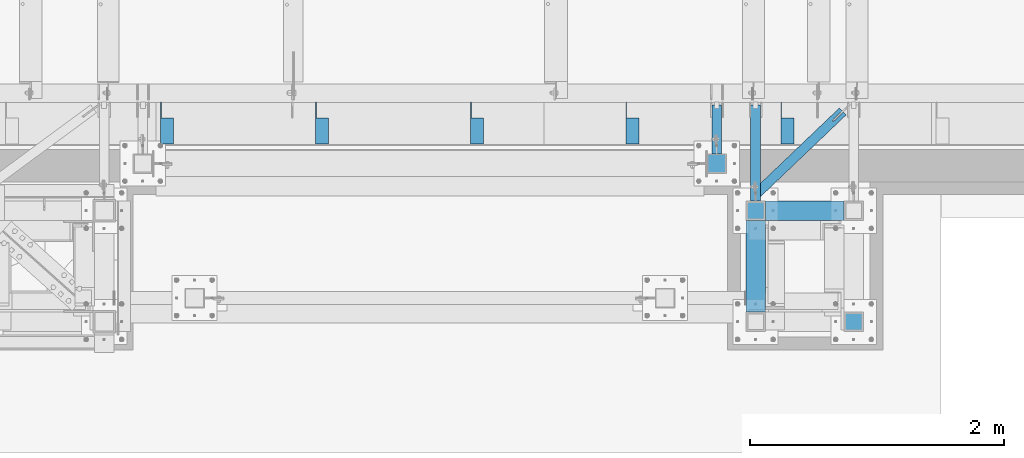
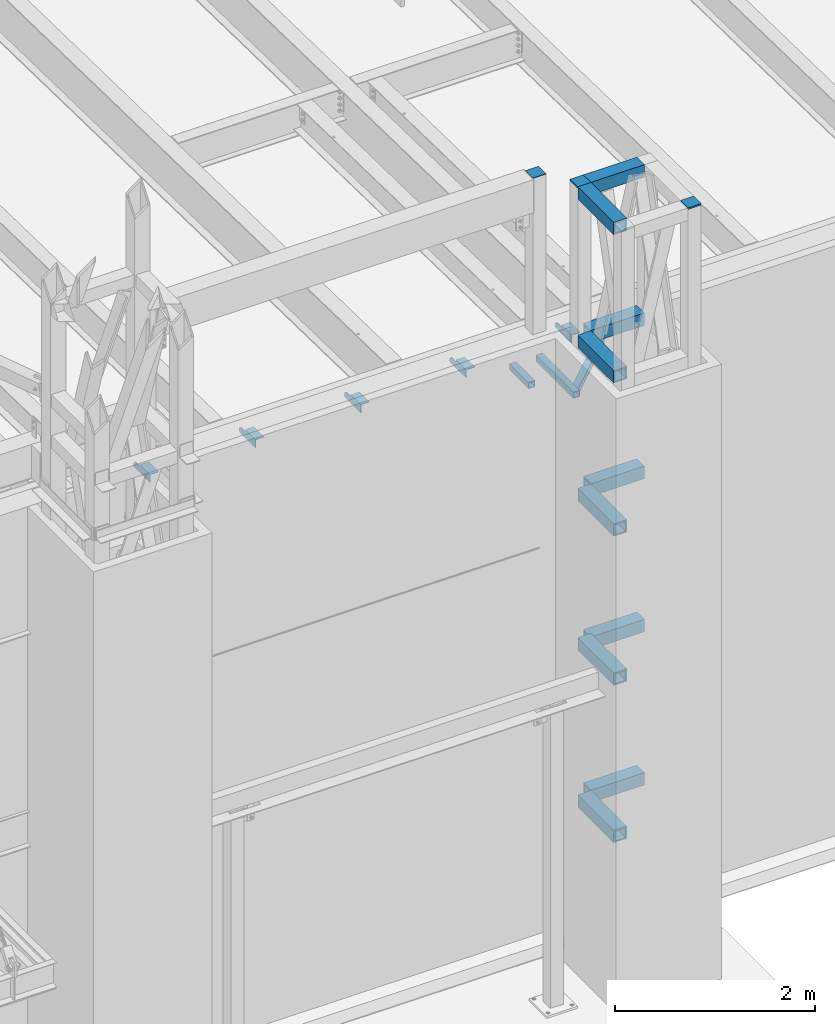
# One storey, part 1211 of 1763: 21 beams, 6 elements without a shape of their own.
"""IFC2X3 building model written with IfcOpenShell, lengths in millimetres."""

from ifc_helpers import new_model, si_unit, frame, origin_with_axes, place, context, subcontext, project, spatial, faceted_brep, material, type_object, element, aggregate, save


model = new_model("IFC2X3")

# Units and contexts
model_context = context("Model", 3, precision=1e-05, world=origin_with_axes())
body_context = subcontext(model_context, "Body", "Model", "MODEL_VIEW")
ifc_project = project(units=[si_unit("LENGTHUNIT", "METRE", prefix="MILLI"), si_unit("AREAUNIT", "SQUARE_METRE"), si_unit("VOLUMEUNIT", "CUBIC_METRE"), si_unit("MASSUNIT", "GRAM", prefix="KILO"), si_unit("TIMEUNIT", "SECOND"), si_unit("PLANEANGLEUNIT", "RADIAN"), si_unit("SOLIDANGLEUNIT", "STERADIAN"), si_unit("THERMODYNAMICTEMPERATUREUNIT", "DEGREE_CELSIUS"), si_unit("LUMINOUSINTENSITYUNIT", "LUMEN")], contexts=[model_context])

# Site, building, storey
site_placement = place(None, origin_with_axes())
site = spatial("IfcSite", under=ifc_project, at=site_placement, CompositionType="ELEMENT")
building_placement = place(site_placement, origin_with_axes())
building = spatial("IfcBuilding", under=site, at=building_placement, Name="Undefined", CompositionType="ELEMENT")
storey_placement = place(building_placement, origin_with_axes())
storey = spatial("IfcBuildingStorey", under=building, at=storey_placement, Name="Undefined", CompositionType="ELEMENT", Elevation=0.0)

# Assembly, beams
assembly_1_placement = place(storey_placement, origin_with_axes())
assembly_1 = element("IfcElementAssembly", 1, at=assembly_1_placement, inside=storey, Name="BEAM", AssemblyPlace="NOTDEFINED", PredefinedType="RIGID_FRAME")
ifc_material_1 = material(Name="STEEL/A36")
beam_type_1 = type_object("IfcBeamType", Name="L4X4X1/4", PredefinedType="NOTDEFINED")
beam_1_placement = place(assembly_1_placement, frame((-41389.6055562795, -13723.9373186166, 12153.8999999999), z_axis=(0.0, 0.0, -1.0), x_axis=(0.0, -1.0, 0.0)))
beam_1 = element("IfcBeam", 2, at=beam_1_placement, type_object=beam_type_1, material=ifc_material_1, Name="BRACE", ObjectType="L4X4X1/4", context=body_context, shape_type="Brep", body=[
    faceted_brep([(126.999999999967, 44.4499999999971, -25.4000000000069), (126.999999999967, 50.8000000000029, -25.4000000000069), (127.0, 50.7999999999993, -50.7999999999993), (127.0, -50.7999999999993, -50.7999999999993), (126.999999999965, -50.8000000000029, -44.4500000000007), (126.999999999965, 44.4499999999971, -44.4500000000007), (31.7499999999691, 44.4499999999971, -25.3999994277547), (31.7499999999691, 50.8000000000029, -25.3999994277547), (-1.81898940354586e-10, 44.4500000000371, 50.7999999999374), (-1.96450855582952e-10, 50.8000000000393, 50.7999999999374), (0.0, 50.8000000000029, 6.35000057224534), (0.0, 44.4499999999971, 6.35000057224534), (328.612481689444, 44.4499999999971, 50.7999999999993), (328.612481689444, 50.8000000000029, 50.7999999999993), (328.612512206997, 44.4499999999971, -44.4500000000007), (328.612512206997, -50.8000000000029, -44.4500000000007), (328.612512206997, -50.8000000000029, -50.7999999999993), (328.612512206997, 50.8000000000029, -50.7999999999993)], [[[0, 1, 2, 3, 4, 5]], [[6, 7, 1, 0]], [[8, 9, 10, 11]], [[9, 8, 12, 13]], [[12, 14, 15, 16, 17, 13]], [[15, 14, 5, 4]], [[16, 15, 4, 3]], [[17, 16, 3, 2]], [[10, 9, 13, 17, 2, 1, 7]], [[11, 10, 7, 6]], [[14, 12, 8, 11, 6, 0, 5]]]),
])
beam_2_placement = place(assembly_1_placement, frame((-42608.8055562795, -13723.9373186167, 12153.8999999999), z_axis=(0.0, 0.0, -1.0), x_axis=(0.0, -1.0, 0.0)))
beam_2 = element("IfcBeam", 3, at=beam_2_placement, type_object=beam_type_1, material=ifc_material_1, Name="BRACE", ObjectType="L4X4X1/4", context=body_context, shape_type="Brep", body=[
    faceted_brep([(126.999999999967, 44.4499999999971, -25.4000000000069), (126.999999999967, 50.8000000000029, -25.4000000000069), (127.0, 50.7999999999993, -50.7999999999993), (127.0, -50.7999999999993, -50.7999999999993), (126.999999999965, -50.8000000000029, -44.4500000000007), (126.999999999965, 44.4499999999971, -44.4500000000007), (31.7499999999691, 44.4499999999971, -25.3999994277547), (31.7499999999691, 50.8000000000029, -25.3999994277547), (-1.81898940354586e-10, 44.4500000000371, 50.7999999999374), (-1.96450855582952e-10, 50.8000000000393, 50.7999999999374), (0.0, 50.8000000000029, 6.35000057224534), (0.0, 44.4499999999971, 6.35000057224534), (328.612481689444, 44.4499999999971, 50.7999999999993), (328.612481689444, 50.8000000000029, 50.7999999999993), (328.612512206997, 44.4499999999971, -44.4500000000007), (328.612512206997, -50.8000000000029, -44.4500000000007), (328.612512206997, -50.8000000000029, -50.7999999999993), (328.612512206997, 50.8000000000029, -50.7999999999993)], [[[0, 1, 2, 3, 4, 5]], [[6, 7, 1, 0]], [[8, 9, 10, 11]], [[9, 8, 12, 13]], [[12, 14, 15, 16, 17, 13]], [[15, 14, 5, 4]], [[16, 15, 4, 3]], [[17, 16, 3, 2]], [[10, 9, 13, 17, 2, 1, 7]], [[11, 10, 7, 6]], [[14, 12, 8, 11, 6, 0, 5]]]),
])
beam_3_placement = place(assembly_1_placement, frame((-43828.0055562796, -13723.9373186167, 12153.8999999999), z_axis=(0.0, 0.0, -1.0), x_axis=(0.0, -1.0, 0.0)))
beam_3 = element("IfcBeam", 4, at=beam_3_placement, type_object=beam_type_1, material=ifc_material_1, Name="BRACE", ObjectType="L4X4X1/4", context=body_context, shape_type="Brep", body=[
    faceted_brep([(126.999999999967, 44.4499999999971, -25.4000000000069), (126.999999999967, 50.8000000000029, -25.4000000000069), (127.0, 50.7999999999993, -50.7999999999993), (127.0, -50.7999999999993, -50.7999999999993), (126.999999999965, -50.8000000000029, -44.4500000000007), (126.999999999965, 44.4499999999971, -44.4500000000007), (31.7499999999691, 44.4499999999971, -25.3999994277547), (31.7499999999691, 50.8000000000029, -25.3999994277547), (-1.81898940354586e-10, 44.4500000000371, 50.7999999999374), (-1.96450855582952e-10, 50.8000000000393, 50.7999999999374), (0.0, 50.8000000000029, 6.35000057224534), (0.0, 44.4499999999971, 6.35000057224534), (328.612481689444, 44.4499999999971, 50.7999999999993), (328.612481689444, 50.8000000000029, 50.7999999999993), (328.612512206997, 44.4499999999971, -44.4500000000007), (328.612512206997, -50.8000000000029, -44.4500000000007), (328.612512206997, -50.8000000000029, -50.7999999999993), (328.612512206997, 50.8000000000029, -50.7999999999993)], [[[0, 1, 2, 3, 4, 5]], [[6, 7, 1, 0]], [[8, 9, 10, 11]], [[9, 8, 12, 13]], [[12, 14, 15, 16, 17, 13]], [[15, 14, 5, 4]], [[16, 15, 4, 3]], [[17, 16, 3, 2]], [[10, 9, 13, 17, 2, 1, 7]], [[11, 10, 7, 6]], [[14, 12, 8, 11, 6, 0, 5]]]),
])
beam_4_placement = place(assembly_1_placement, frame((-45047.2055562796, -13723.9373186168, 12153.8999999999), z_axis=(0.0, 0.0, -1.0), x_axis=(0.0, -1.0, 0.0)))
beam_4 = element("IfcBeam", 5, at=beam_4_placement, type_object=beam_type_1, material=ifc_material_1, Name="BRACE", ObjectType="L4X4X1/4", context=body_context, shape_type="Brep", body=[
    faceted_brep([(126.999999999967, 44.4499999999971, -25.4000000000069), (126.999999999967, 50.8000000000029, -25.4000000000069), (127.0, 50.7999999999993, -50.7999999999993), (127.0, -50.7999999999993, -50.7999999999993), (126.999999999965, -50.8000000000029, -44.4500000000007), (126.999999999965, 44.4499999999971, -44.4500000000007), (31.7499999999691, 44.4499999999971, -25.3999994277547), (31.7499999999691, 50.8000000000029, -25.3999994277547), (-1.81898940354586e-10, 44.4500000000371, 50.7999999999374), (-1.96450855582952e-10, 50.8000000000393, 50.7999999999374), (0.0, 50.8000000000029, 6.35000057224534), (0.0, 44.4499999999971, 6.35000057224534), (328.612481689444, 44.4499999999971, 50.7999999999993), (328.612481689444, 50.8000000000029, 50.7999999999993), (328.612512206997, 44.4499999999971, -44.4500000000007), (328.612512206997, -50.8000000000029, -44.4500000000007), (328.612512206997, -50.8000000000029, -50.7999999999993), (328.612512206997, 50.8000000000029, -50.7999999999993)], [[[0, 1, 2, 3, 4, 5]], [[6, 7, 1, 0]], [[8, 9, 10, 11]], [[9, 8, 12, 13]], [[12, 14, 15, 16, 17, 13]], [[15, 14, 5, 4]], [[16, 15, 4, 3]], [[17, 16, 3, 2]], [[10, 9, 13, 17, 2, 1, 7]], [[11, 10, 7, 6]], [[14, 12, 8, 11, 6, 0, 5]]]),
])
beam_5_placement = place(assembly_1_placement, frame((-46266.4055562795, -13723.9373186169, 12153.8999999999), z_axis=(0.0, 0.0, -1.0), x_axis=(0.0, -1.0, 0.0)))
beam_5 = element("IfcBeam", 6, at=beam_5_placement, type_object=beam_type_1, material=ifc_material_1, Name="BRACE", ObjectType="L4X4X1/4", context=body_context, shape_type="Brep", body=[
    faceted_brep([(126.999999999967, 44.4499999999971, -25.4000000000069), (126.999999999967, 50.8000000000029, -25.4000000000069), (127.0, 50.7999999999993, -50.7999999999993), (127.0, -50.7999999999993, -50.7999999999993), (126.999999999965, -50.8000000000029, -44.4500000000007), (126.999999999965, 44.4499999999971, -44.4500000000007), (31.7499999999691, 44.4499999999971, -25.3999994277547), (31.7499999999691, 50.8000000000029, -25.3999994277547), (-1.81898940354586e-10, 44.4500000000371, 50.7999999999374), (-1.96450855582952e-10, 50.8000000000393, 50.7999999999374), (0.0, 50.8000000000029, 6.35000057224534), (0.0, 44.4499999999971, 6.35000057224534), (328.612481689444, 44.4499999999971, 50.7999999999993), (328.612481689444, 50.8000000000029, 50.7999999999993), (328.612512206997, 44.4499999999971, -44.4500000000007), (328.612512206997, -50.8000000000029, -44.4500000000007), (328.612512206997, -50.8000000000029, -50.7999999999993), (328.612512206997, 50.8000000000029, -50.7999999999993)], [[[0, 1, 2, 3, 4, 5]], [[6, 7, 1, 0]], [[8, 9, 10, 11]], [[9, 8, 12, 13]], [[12, 14, 15, 16, 17, 13]], [[15, 14, 5, 4]], [[16, 15, 4, 3]], [[17, 16, 3, 2]], [[10, 9, 13, 17, 2, 1, 7]], [[11, 10, 7, 6]], [[14, 12, 8, 11, 6, 0, 5]]]),
])
aggregate(assembly_1, [beam_1, beam_2, beam_3, beam_4, beam_5])

# Assembly, beam
assembly_2_placement = place(storey_placement, origin_with_axes())
assembly_2 = element("IfcElementAssembly", 7, at=assembly_2_placement, inside=storey, Name="BEAM", AssemblyPlace="NOTDEFINED", PredefinedType="RIGID_FRAME")
ifc_material_2 = material()
beam_type_2 = type_object("IfcBeamType", Name="HSS3X3X1/4", PredefinedType="NOTDEFINED")
beam_6_placement = place(assembly_2_placement, frame((-41944.780256172, -14131.9264769908, 11820.525), z_axis=(0.0, 0.0, 1.0), x_axis=(0.0, 1.0, 0.0)))
beam_6 = element("IfcBeam", 8, at=beam_6_placement, type_object=beam_type_2, material=ifc_material_2, Name="BEAM", ObjectType="HSS3X3X1/4", context=body_context, shape_type="Brep", body=[
    faceted_brep([(0.0, 31.75, -31.75), (0.0, -31.75, -31.75), (382.589158373732, -31.75, -31.75), (382.589158373732, 31.75, -31.75), (0.0, -31.75, 31.75), (382.589158373732, -31.75, 31.75), (0.0, 31.75, 31.75), (382.589158373732, 31.75, 31.75), (0.0, 38.0999999999985, -38.1000000000004), (0.0, 38.0999999999985, 38.1000000000004), (382.589158373732, 38.0999999999985, 38.1000000000004), (382.589158373732, 38.0999999999985, -38.1000000000004), (0.0, -38.0999999999985, 38.1000000000004), (382.589158373732, -38.0999999999985, 38.1000000000004), (0.0, -38.0999999999985, -38.1000000000004), (382.589158373732, -38.0999999999985, -38.1000000000004)], [[[0, 1, 2, 3]], [[1, 4, 5, 2]], [[4, 6, 7, 5]], [[6, 0, 3, 7]], [[8, 9, 10, 11]], [[9, 12, 13, 10]], [[12, 14, 15, 13]], [[14, 8, 11, 15]], [[13, 15, 11, 10], [5, 7, 3, 2]], [[14, 12, 9, 8], [6, 4, 1, 0]]]),
])
aggregate(assembly_2, [beam_6])

assembly_3_placement = place(storey_placement, origin_with_axes())
assembly_3 = element("IfcElementAssembly", 9, at=assembly_3_placement, inside=storey, Name="BEAM", AssemblyPlace="NOTDEFINED", PredefinedType="RIGID_FRAME")
beam_7_placement = place(assembly_3_placement, frame((-41639.5634959181, -14452.5306029674, 11820.525), z_axis=(0.0, 0.0, 1.0), x_axis=(0.723320631729244, 0.690512319741514, 0.0)))
beam_7 = element("IfcBeam", 10, at=beam_7_placement, type_object=beam_type_2, material=ifc_material_2, Name="BEAM", ObjectType="HSS3X3X1/4", context=body_context, shape_type="Brep", body=[
    faceted_brep([(946.871423137745, 6.35000031700474, 38.1000000000004), (838.921423119747, 6.35000023934117, 38.1000000000004), (838.921423119747, 6.35000023933389, 31.75), (946.871423137745, 6.35000031700474, 31.75), (838.921423128813, -6.34999976050312, 38.1000000000004), (838.921423128799, -6.34999976049585, 31.75), (946.871423137658, -6.34999968283228, 38.1000000000004), (946.871423137658, -6.34999968283228, 31.75), (946.871423137745, 6.35000031700474, -31.75), (838.92142311966, 6.35000023933389, -31.75), (838.921423119638, 6.35000023933389, -38.1000000000004), (946.871423137745, 6.35000031700474, -38.1000000000004), (838.921423128711, -6.3499997605104, -31.75), (838.921423128697, -6.34999976049585, -38.1000000000004), (946.871423137658, -6.34999968283228, -31.75), (946.871423137658, -6.34999968283228, -38.1000000000004), (82.9836498048971, 31.75, 31.75), (82.9836498048971, 31.75, -31.75), (946.871423137905, 31.7500000014479, -31.75), (946.871423137905, 31.7500000014479, 31.75), (946.871423137498, -31.7499999982829, 31.75), (22.3638470663718, -31.7499999998254, 31.75), (22.3638470663718, -31.7499999998254, -31.75), (946.871423137498, -31.7499999982829, -31.75), (16.3018667925207, -38.0999999998094, -38.1000000000004), (16.3018667925207, -38.0999999998094, 38.1000000000004), (89.0456300787482, 38.099999999984, 38.1000000000004), (89.0456300787482, 38.099999999984, -38.1000000000004), (946.871423137949, 38.1000000014174, 38.1000000000004), (946.871423137949, 38.1000000014174, -38.1000000000004), (946.871423137447, -38.0999999982596, -38.1000000000004), (946.871423137447, -38.0999999982596, 38.1000000000004)], [[[0, 1, 2, 3]], [[4, 5, 2, 1]], [[6, 7, 5, 4]], [[8, 9, 10, 11]], [[12, 13, 10, 9]], [[14, 15, 13, 12]], [[16, 17, 18, 19]], [[20, 21, 16, 19, 3, 2, 5, 7]], [[22, 21, 20, 23]], [[9, 8, 18, 17, 22, 23, 14, 12]], [[24, 25, 26, 27], [16, 21, 22, 17]], [[27, 26, 28, 29]], [[19, 18, 8, 11, 29, 28, 0, 3]], [[30, 24, 27, 29, 11, 10, 13, 15]], [[25, 24, 30, 31]], [[1, 0, 28, 26, 25, 31, 6, 4]], [[31, 30, 15, 14, 23, 20, 7, 6]]]),
])
aggregate(assembly_3, [beam_7])

assembly_4_placement = place(storey_placement, origin_with_axes())
assembly_4 = element("IfcElementAssembly", 11, at=assembly_4_placement, inside=storey, Name="BEAM", AssemblyPlace="NOTDEFINED", PredefinedType="RIGID_FRAME")
beam_8_placement = place(assembly_4_placement, frame((-41639.5634959181, -14503.3306029674, 11820.525), z_axis=(0.0, 0.0, 1.0), x_axis=(0.0, 1.0, 0.0)))
beam_8 = element("IfcBeam", 12, at=beam_8_placement, type_object=beam_type_2, material=ifc_material_2, Name="BEAM", ObjectType="HSS3X3X1/4", context=body_context, shape_type="Brep", body=[
    faceted_brep([(0.0, 31.75, -31.75), (0.0, -31.75, -31.75), (753.993284350292, -31.75, -31.75), (753.993284350292, 31.75, -31.75), (0.0, -31.75, 31.75), (753.993284350292, -31.75, 31.75), (0.0, 31.75, 31.75), (753.993284350292, 31.75, 31.75), (0.0, 38.0999999999985, -38.1000000000004), (0.0, 38.0999999999985, 38.1000000000004), (753.993284350292, 38.0999999999985, 38.1000000000004), (753.993284350292, 38.0999999999985, -38.1000000000004), (0.0, -38.0999999999985, 38.1000000000004), (753.993284350292, -38.0999999999985, 38.1000000000004), (0.0, -38.0999999999985, -38.1000000000004), (753.993284350292, -38.0999999999985, -38.1000000000004)], [[[0, 1, 2, 3]], [[1, 4, 5, 2]], [[4, 6, 7, 5]], [[6, 0, 3, 7]], [[8, 9, 10, 11]], [[9, 12, 13, 10]], [[12, 14, 15, 13]], [[14, 8, 11, 15]], [[13, 15, 11, 10], [5, 7, 3, 2]], [[14, 12, 9, 8], [6, 4, 1, 0]]]),
])
aggregate(assembly_4, [beam_8])

# Assembly, beams
assembly_5_placement = place(storey_placement, origin_with_axes())
assembly_5 = element("IfcElementAssembly", 13, at=assembly_5_placement, inside=storey, Name="FRAME", AssemblyPlace="NOTDEFINED", PredefinedType="RIGID_FRAME")
beam_type_3 = type_object("IfcBeamType", PredefinedType="NOTDEFINED")
beam_9_placement = place(assembly_5_placement, frame((-41639.5634959181, -14655.7306029674, 14468.475), z_axis=(1.0, 0.0, 0.0), x_axis=(0.0, 1.0, 0.0)))
beam_9 = element("IfcBeam", 14, at=beam_9_placement, type_object=beam_type_3, material=ifc_material_1, Name="PLATE", context=body_context, shape_type="Brep", body=[
    faceted_brep([(0.0, 9.52499999999964, -76.1999999999971), (0.0, 9.52499999999964, 76.1999999999971), (152.400000000001, 9.52499999999964, 76.1999999999971), (152.400000000001, 9.52499999999964, -76.1999999999971), (0.0, -9.52499999999964, 76.1999999999971), (152.400000000001, -9.52499999999964, 76.1999999999971), (0.0, -9.52499999999964, -76.1999999999971), (152.400000000001, -9.52499999999964, -76.1999999999971)], [[[0, 1, 2, 3]], [[1, 4, 5, 2]], [[4, 6, 7, 5]], [[6, 0, 3, 7]], [[5, 7, 3, 2]], [[6, 4, 1, 0]]]),
])
beam_10_placement = place(assembly_5_placement, frame((-40868.0383006056, -15528.8556029674, 14468.475), z_axis=(1.0, 0.0, 0.0), x_axis=(0.0, 1.0, 0.0)))
beam_10 = element("IfcBeam", 15, at=beam_10_placement, type_object=beam_type_3, material=ifc_material_1, Name="PLATE", context=body_context, shape_type="Brep", body=[
    faceted_brep([(0.0, 9.52499999999964, -76.1999999999971), (0.0, 9.52499999999964, 76.1999999999971), (152.400000000001, 9.52499999999964, 76.1999999999971), (152.400000000001, 9.52499999999964, -76.1999999999971), (0.0, -9.52499999999964, 76.1999999999971), (152.400000000001, -9.52499999999964, 76.1999999999971), (0.0, -9.52499999999964, -76.1999999999971), (152.400000000001, -9.52499999999964, -76.1999999999971)], [[[0, 1, 2, 3]], [[1, 4, 5, 2]], [[4, 6, 7, 5]], [[6, 0, 3, 7]], [[5, 7, 3, 2]], [[6, 4, 1, 0]]]),
])
beam_type_4 = type_object("IfcBeamType", Name="HSS6X6X5/8", PredefinedType="NOTDEFINED")
beam_11_placement = place(assembly_5_placement, frame((-41639.5633006091, -14579.5306029674, 6966.74375), z_axis=(0.0, 0.0, 1.0), x_axis=(1.0, 0.0, 0.0)))
beam_11 = element("IfcBeam", 16, at=beam_11_placement, type_object=beam_type_4, material=ifc_material_2, Name="BEAM", ObjectType="HSS6X6X5/8", context=body_context, shape_type="Brep", body=[
    faceted_brep([(76.1998535156017, 60.3250000000007, -60.3249999999998), (76.1998535156017, -60.3250000000007, -60.3249999999998), (695.325048828119, -60.3250000000007, -60.3249999999998), (695.325048828119, 60.3250000000007, -60.3249999999998), (76.1998535156017, -60.3250000000007, 60.3249999999998), (695.325048828119, -60.3250000000007, 60.3249999999998), (76.1998535156017, 60.3250000000007, 60.3249999999998), (695.325048828119, 60.3250000000007, 60.3249999999998), (76.1998535156017, 76.2000000000007, -76.1999999999998), (76.1998535156017, 76.2000000000007, 76.1999999999998), (695.325048828119, 76.2000000000007, 76.1999999999998), (695.325048828119, 76.2000000000007, -76.1999999999998), (76.1998535156017, -76.2000000000007, 76.1999999999998), (695.325048828119, -76.2000000000007, 76.1999999999998), (76.1998535156017, -76.2000000000007, -76.1999999999998), (695.325048828119, -76.2000000000007, -76.1999999999998)], [[[0, 1, 2, 3]], [[1, 4, 5, 2]], [[4, 6, 7, 5]], [[6, 0, 3, 7]], [[8, 9, 10, 11]], [[9, 12, 13, 10]], [[12, 14, 15, 13]], [[14, 8, 11, 15]], [[13, 15, 11, 10], [5, 7, 3, 2]], [[14, 12, 9, 8], [6, 4, 1, 0]]]),
])
beam_12_placement = place(assembly_5_placement, frame((-41639.5633006091, -15452.6556029674, 6966.74375), z_axis=(0.0, 0.0, 1.0), x_axis=(0.0, 1.0, 0.0)))
beam_12 = element("IfcBeam", 17, at=beam_12_placement, type_object=beam_type_4, material=ifc_material_2, Name="BEAM", ObjectType="HSS6X6X5/8", context=body_context, shape_type="Brep", body=[
    faceted_brep([(76.1999511718459, 60.3250000000007, -60.3250000000007), (76.1999511718459, -60.3250000000007, -60.3250000000007), (796.924999999999, -60.3249999999971, -60.3249999999998), (796.924999999999, 60.3249999999971, -60.3249999999998), (76.1999511718459, -60.3250000000007, 60.3250000000007), (796.924999999999, -60.3249999999971, 60.3249999999998), (76.1999511718459, 60.3250000000007, 60.3250000000007), (796.924999999999, 60.3249999999971, 60.3249999999998), (76.1999511718459, 76.2000000000007, -76.2000000000007), (76.1999511718459, 76.2000000000007, 76.2000000000007), (796.924999999999, 76.1999999999971, 76.1999999999998), (796.924999999999, 76.1999999999971, -76.1999999999998), (76.1999511718459, -76.2000000000007, 76.2000000000007), (796.924999999999, -76.1999999999971, 76.1999999999998), (76.1999511718459, -76.2000000000007, -76.2000000000007), (796.924999999999, -76.1999999999971, -76.1999999999998)], [[[0, 1, 2, 3]], [[1, 4, 5, 2]], [[4, 6, 7, 5]], [[6, 0, 3, 7]], [[8, 9, 10, 11]], [[9, 12, 13, 10]], [[12, 14, 15, 13]], [[14, 8, 11, 15]], [[13, 15, 11, 10], [5, 7, 3, 2]], [[14, 12, 9, 8], [6, 4, 1, 0]]]),
])
beam_13_placement = place(assembly_5_placement, frame((-41639.5633006125, -14579.5306029674, 8840.7875), z_axis=(0.0, 0.0, 1.0), x_axis=(1.0, 0.0, 0.0)))
beam_13 = element("IfcBeam", 18, at=beam_13_placement, type_object=beam_type_4, material=ifc_material_2, Name="BEAM", ObjectType="HSS6X6X5/8", context=body_context, shape_type="Brep", body=[
    faceted_brep([(76.1999511718459, 60.3250000000007, -60.3250000000007), (76.1999511718459, -60.3250000000007, -60.3250000000007), (695.325146484363, -60.3250000000007, -60.3250000000007), (695.325146484363, 60.3250000000007, -60.3250000000007), (76.1999511718459, -60.3250000000007, 60.3250000000007), (695.325146484363, -60.3250000000007, 60.3250000000007), (76.1999511718459, 60.3250000000007, 60.3250000000007), (695.325146484363, 60.3250000000007, 60.3250000000007), (76.1999511718459, 76.2000000000007, -76.2000000000007), (76.1999511718459, 76.2000000000007, 76.2000000000007), (695.325146484363, 76.2000000000007, 76.2000000000007), (695.325146484363, 76.2000000000007, -76.2000000000007), (76.1999511718459, -76.2000000000007, 76.2000000000007), (695.325146484363, -76.2000000000007, 76.2000000000007), (76.1999511718459, -76.2000000000007, -76.2000000000007), (695.325146484363, -76.2000000000007, -76.2000000000007)], [[[0, 1, 2, 3]], [[1, 4, 5, 2]], [[4, 6, 7, 5]], [[6, 0, 3, 7]], [[8, 9, 10, 11]], [[9, 12, 13, 10]], [[12, 14, 15, 13]], [[14, 8, 11, 15]], [[13, 15, 11, 10], [5, 7, 3, 2]], [[14, 12, 9, 8], [6, 4, 1, 0]]]),
])
beam_14_placement = place(assembly_5_placement, frame((-41639.5633006125, -15452.6556029674, 8890.0), z_axis=(0.0, 0.0, 1.0), x_axis=(0.0, 1.0, 0.0)))
beam_14 = element("IfcBeam", 19, at=beam_14_placement, type_object=beam_type_4, material=ifc_material_2, Name="BEAM", ObjectType="HSS6X6X5/8", context=body_context, shape_type="Brep", body=[
    faceted_brep([(76.1999511718459, 60.3250000000007, -60.3250000000007), (76.1999511718459, -60.3250000000007, -60.3250000000007), (796.924999999999, -60.3249999999971, -60.3249999999998), (796.924999999999, 60.3249999999971, -60.3249999999998), (76.1999511718459, -60.3250000000007, 60.3250000000007), (796.924999999999, -60.3249999999971, 60.3249999999998), (76.1999511718459, 60.3250000000007, 60.3250000000007), (796.924999999999, 60.3249999999971, 60.3249999999998), (76.1999511718459, 76.2000000000007, -76.2000000000007), (76.1999511718459, 76.2000000000007, 76.2000000000007), (796.924999999999, 76.1999999999971, 76.1999999999998), (796.924999999999, 76.1999999999971, -76.1999999999998), (76.1999511718459, -76.2000000000007, 76.2000000000007), (796.924999999999, -76.1999999999971, 76.1999999999998), (76.1999511718459, -76.2000000000007, -76.2000000000007), (796.924999999999, -76.1999999999971, -76.1999999999998)], [[[0, 1, 2, 3]], [[1, 4, 5, 2]], [[4, 6, 7, 5]], [[6, 0, 3, 7]], [[8, 9, 10, 11]], [[9, 12, 13, 10]], [[12, 14, 15, 13]], [[14, 8, 11, 15]], [[13, 15, 11, 10], [5, 7, 3, 2]], [[14, 12, 9, 8], [6, 4, 1, 0]]]),
])
beam_15_placement = place(assembly_5_placement, frame((-41639.5633006159, -14579.5306029674, 10714.83125), z_axis=(0.0, 0.0, 1.0), x_axis=(1.0, 0.0, 0.0)))
beam_15 = element("IfcBeam", 20, at=beam_15_placement, type_object=beam_type_4, material=ifc_material_2, Name="BEAM", ObjectType="HSS6X6X5/8", context=body_context, shape_type="Brep", body=[
    faceted_brep([(76.1999511718459, 60.3250000000007, -60.3250000000007), (76.1999511718459, -60.3250000000007, -60.3250000000007), (695.325146484363, -60.3250000000007, -60.3250000000007), (695.325146484363, 60.3250000000007, -60.3250000000007), (76.1999511718459, -60.3250000000007, 60.3250000000007), (695.325146484363, -60.3250000000007, 60.3250000000007), (76.1999511718459, 60.3250000000007, 60.3250000000007), (695.325146484363, 60.3250000000007, 60.3250000000007), (76.1999511718459, 76.2000000000007, -76.2000000000007), (76.1999511718459, 76.2000000000007, 76.2000000000007), (695.325146484363, 76.2000000000007, 76.2000000000007), (695.325146484363, 76.2000000000007, -76.2000000000007), (76.1999511718459, -76.2000000000007, 76.2000000000007), (695.325146484363, -76.2000000000007, 76.2000000000007), (76.1999511718459, -76.2000000000007, -76.2000000000007), (695.325146484363, -76.2000000000007, -76.2000000000007)], [[[0, 1, 2, 3]], [[1, 4, 5, 2]], [[4, 6, 7, 5]], [[6, 0, 3, 7]], [[8, 9, 10, 11]], [[9, 12, 13, 10]], [[12, 14, 15, 13]], [[14, 8, 11, 15]], [[13, 15, 11, 10], [5, 7, 3, 2]], [[14, 12, 9, 8], [6, 4, 1, 0]]]),
])
beam_16_placement = place(assembly_5_placement, frame((-41639.5633006159, -15452.6556029674, 10714.83125), z_axis=(0.0, 0.0, 1.0), x_axis=(0.0, 1.0, 0.0)))
beam_16 = element("IfcBeam", 21, at=beam_16_placement, type_object=beam_type_4, material=ifc_material_2, Name="BEAM", ObjectType="HSS6X6X5/8", context=body_context, shape_type="Brep", body=[
    faceted_brep([(76.1999511718459, 60.3250000000007, -60.3250000000007), (76.1999511718459, -60.3250000000007, -60.3250000000007), (796.924999999999, -60.3249999999971, -60.3249999999998), (796.924999999999, 60.3249999999971, -60.3249999999998), (76.1999511718459, -60.3250000000007, 60.3250000000007), (796.924999999999, -60.3249999999971, 60.3249999999998), (76.1999511718459, 60.3250000000007, 60.3250000000007), (796.924999999999, 60.3249999999971, 60.3249999999998), (76.1999511718459, 76.2000000000007, -76.2000000000007), (76.1999511718459, 76.2000000000007, 76.2000000000007), (796.924999999999, 76.1999999999971, 76.1999999999998), (796.924999999999, 76.1999999999971, -76.1999999999998), (76.1999511718459, -76.2000000000007, 76.2000000000007), (796.924999999999, -76.1999999999971, 76.1999999999998), (76.1999511718459, -76.2000000000007, -76.2000000000007), (796.924999999999, -76.1999999999971, -76.1999999999998)], [[[0, 1, 2, 3]], [[1, 4, 5, 2]], [[4, 6, 7, 5]], [[6, 0, 3, 7]], [[8, 9, 10, 11]], [[9, 12, 13, 10]], [[12, 14, 15, 13]], [[14, 8, 11, 15]], [[13, 15, 11, 10], [5, 7, 3, 2]], [[14, 12, 9, 8], [6, 4, 1, 0]]]),
])
beam_17_placement = place(assembly_5_placement, frame((-41639.5634959351, -14579.5306029674, 14401.8), z_axis=(0.0, 0.0, 1.0), x_axis=(1.0, 0.0, 0.0)))
beam_17 = element("IfcBeam", 22, at=beam_17_placement, type_object=beam_type_4, material=ifc_material_2, Name="BEAM", ObjectType="HSS6X6X5/8", context=body_context, shape_type="Brep", body=[
    faceted_brep([(76.2001955583473, 60.3250000000007, -60.3250000000007), (76.2001955583473, -60.3250000000007, -60.3250000000007), (695.32539087085, -60.3250000000007, -60.3250000000007), (695.32539087085, 60.3250000000007, -60.3250000000007), (76.2001980919958, -60.3250000000007, 60.3250000000007), (695.325393404499, -60.3250000000007, 60.3250000000007), (76.2001980919958, 60.3250000000007, 60.3250000000007), (695.325393404499, 60.3250000000007, 60.3250000000007), (76.2001952249702, 76.2000000000007, -76.2000000000007), (76.2001984253729, 76.2000000000007, 76.2000000000007), (695.325393737876, 76.2000000000007, 76.2000000000007), (695.325390537473, 76.2000000000007, -76.2000000000007), (76.2001984253729, -76.2000000000007, 76.2000000000007), (695.325393737876, -76.2000000000007, 76.2000000000007), (76.2001952249702, -76.2000000000007, -76.2000000000007), (695.325390537473, -76.2000000000007, -76.2000000000007)], [[[0, 1, 2, 3]], [[1, 4, 5, 2]], [[4, 6, 7, 5]], [[6, 0, 3, 7]], [[8, 9, 10, 11]], [[9, 12, 13, 10]], [[12, 14, 15, 13]], [[14, 8, 11, 15]], [[13, 15, 11, 10], [5, 7, 3, 2]], [[14, 12, 9, 8], [6, 4, 1, 0]]]),
])
beam_18_placement = place(assembly_5_placement, frame((-41639.5633006226, -15452.6556029674, 14401.8), z_axis=(0.0, 0.0, 1.0), x_axis=(0.0, 1.0, 0.0)))
beam_18 = element("IfcBeam", 23, at=beam_18_placement, type_object=beam_type_4, material=ifc_material_2, Name="BEAM", ObjectType="HSS6X6X5/8", context=body_context, shape_type="Brep", body=[
    faceted_brep([(76.1999511718459, 60.3250000000007, -60.3250000000007), (76.1999511718459, -60.3250000000007, -60.3250000000007), (796.924999999999, -60.3249999999971, -60.3249999999998), (796.924999999999, 60.3249999999971, -60.3249999999998), (76.1999511718459, -60.3250000000007, 60.3250000000007), (796.924999999999, -60.3249999999971, 60.3249999999998), (76.1999511718459, 60.3250000000007, 60.3250000000007), (796.924999999999, 60.3249999999971, 60.3249999999998), (76.1999511718459, 76.2000000000007, -76.2000000000007), (76.1999511718459, 76.2000000000007, 76.2000000000007), (796.924999999999, 76.1999999999971, 76.1999999999998), (796.924999999999, 76.1999999999971, -76.1999999999998), (76.1999511718459, -76.2000000000007, 76.2000000000007), (796.924999999999, -76.1999999999971, 76.1999999999998), (76.1999511718459, -76.2000000000007, -76.2000000000007), (796.924999999999, -76.1999999999971, -76.1999999999998)], [[[0, 1, 2, 3]], [[1, 4, 5, 2]], [[4, 6, 7, 5]], [[6, 0, 3, 7]], [[8, 9, 10, 11]], [[9, 12, 13, 10]], [[12, 14, 15, 13]], [[14, 8, 11, 15]], [[13, 15, 11, 10], [5, 7, 3, 2]], [[14, 12, 9, 8], [6, 4, 1, 0]]]),
])
beam_19_placement = place(assembly_5_placement, frame((-41639.5633006194, -14579.5306029674, 12588.875), z_axis=(0.0, 0.0, 1.0), x_axis=(1.0, 0.0, 0.0)))
beam_19 = element("IfcBeam", 24, at=beam_19_placement, type_object=beam_type_4, material=ifc_material_2, Name="BEAM", ObjectType="HSS6X6X5/8", context=body_context, shape_type="Brep", body=[
    faceted_brep([(76.1999511718459, 60.3250000000007, -60.3250000000007), (76.1999511718459, -60.3250000000007, -60.3250000000007), (695.325146484363, -60.3250000000007, -60.3250000000007), (695.325146484363, 60.3250000000007, -60.3250000000007), (76.1999511718459, -60.3250000000007, 60.3250000000007), (695.325146484363, -60.3250000000007, 60.3250000000007), (76.1999511718459, 60.3250000000007, 60.3250000000007), (695.325146484363, 60.3250000000007, 60.3250000000007), (76.1999511718459, 76.2000000000007, -76.2000000000007), (76.1999511718459, 76.2000000000007, 76.2000000000007), (695.325146484363, 76.2000000000007, 76.2000000000007), (695.325146484363, 76.2000000000007, -76.2000000000007), (76.1999511718459, -76.2000000000007, 76.2000000000007), (695.325146484363, -76.2000000000007, 76.2000000000007), (76.1999511718459, -76.2000000000007, -76.2000000000007), (695.325146484363, -76.2000000000007, -76.2000000000007)], [[[0, 1, 2, 3]], [[1, 4, 5, 2]], [[4, 6, 7, 5]], [[6, 0, 3, 7]], [[8, 9, 10, 11]], [[9, 12, 13, 10]], [[12, 14, 15, 13]], [[14, 8, 11, 15]], [[13, 15, 11, 10], [5, 7, 3, 2]], [[14, 12, 9, 8], [6, 4, 1, 0]]]),
])
beam_20_placement = place(assembly_5_placement, frame((-41639.5633006194, -15452.6556029674, 12588.875), z_axis=(0.0, 0.0, 1.0), x_axis=(0.0, 1.0, 0.0)))
beam_20 = element("IfcBeam", 25, at=beam_20_placement, type_object=beam_type_4, material=ifc_material_2, Name="BEAM", ObjectType="HSS6X6X5/8", context=body_context, shape_type="Brep", body=[
    faceted_brep([(76.1999511718459, 60.3250000000007, -60.3250000000007), (76.1999511718459, -60.3250000000007, -60.3250000000007), (796.924999999999, -60.3249999999971, -60.3249999999998), (796.924999999999, 60.3249999999971, -60.3249999999998), (76.1999511718459, -60.3250000000007, 60.3250000000007), (796.924999999999, -60.3249999999971, 60.3249999999998), (76.1999511718459, 60.3250000000007, 60.3250000000007), (796.924999999999, 60.3249999999971, 60.3249999999998), (76.1999511718459, 76.2000000000007, -76.2000000000007), (76.1999511718459, 76.2000000000007, 76.2000000000007), (796.924999999999, 76.1999999999971, 76.1999999999998), (796.924999999999, 76.1999999999971, -76.1999999999998), (76.1999511718459, -76.2000000000007, 76.2000000000007), (796.924999999999, -76.1999999999971, 76.1999999999998), (76.1999511718459, -76.2000000000007, -76.2000000000007), (796.924999999999, -76.1999999999971, -76.1999999999998)], [[[0, 1, 2, 3]], [[1, 4, 5, 2]], [[4, 6, 7, 5]], [[6, 0, 3, 7]], [[8, 9, 10, 11]], [[9, 12, 13, 10]], [[12, 14, 15, 13]], [[14, 8, 11, 15]], [[13, 15, 11, 10], [5, 7, 3, 2]], [[14, 12, 9, 8], [6, 4, 1, 0]]]),
])
aggregate(assembly_5, [beam_11, beam_12, beam_13, beam_14, beam_15, beam_16, beam_17, beam_18, beam_19, beam_20, beam_9, beam_10])

# Assembly, beam
assembly_6_placement = place(storey_placement, origin_with_axes())
assembly_6 = element("IfcElementAssembly", 26, at=assembly_6_placement, inside=storey, Name="COLUMN", AssemblyPlace="NOTDEFINED", PredefinedType="RIGID_FRAME")
beam_type_5 = type_object("IfcBeamType", PredefinedType="NOTDEFINED")
beam_21_placement = place(assembly_6_placement, frame((-41944.780256172, -14284.3264769908, 14462.125), z_axis=(1.0, 0.0, 0.0), x_axis=(0.0, 1.0, 0.0)))
beam_21 = element("IfcBeam", 27, at=beam_21_placement, type_object=beam_type_5, material=ifc_material_1, Name="PLATE", context=body_context, shape_type="Brep", body=[
    faceted_brep([(0.0, 3.17500000001746, -76.2000000000007), (-1.51339918375015e-09, 3.17499999999927, 76.1999969482422), (152.399990844715, 3.17500000000291, 76.2000000000007), (152.399990844715, 3.17500000000291, -76.2000000000007), (-1.51339918375015e-09, -3.17499999999927, 76.1999969482422), (152.399990844715, -3.17500000000291, 76.2000000000007), (0.0, -3.17500000000291, -76.2000000000007), (152.399990844715, -3.17500000000291, -76.2000000000007)], [[[0, 1, 2, 3]], [[1, 4, 5, 2]], [[4, 6, 7, 5]], [[6, 0, 3, 7]], [[5, 7, 3, 2]], [[6, 4, 1, 0]]]),
])
aggregate(assembly_6, [beam_21])

save(model, "model.ifc")
